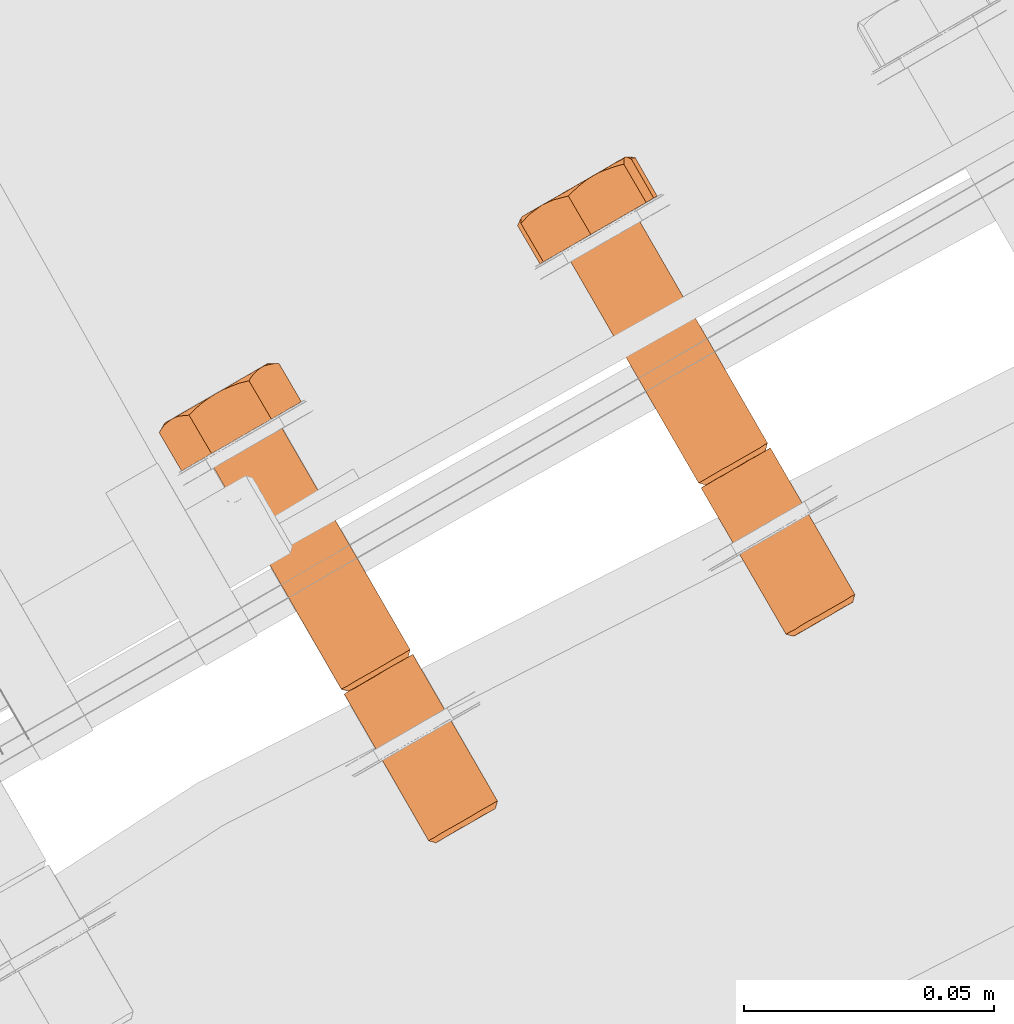
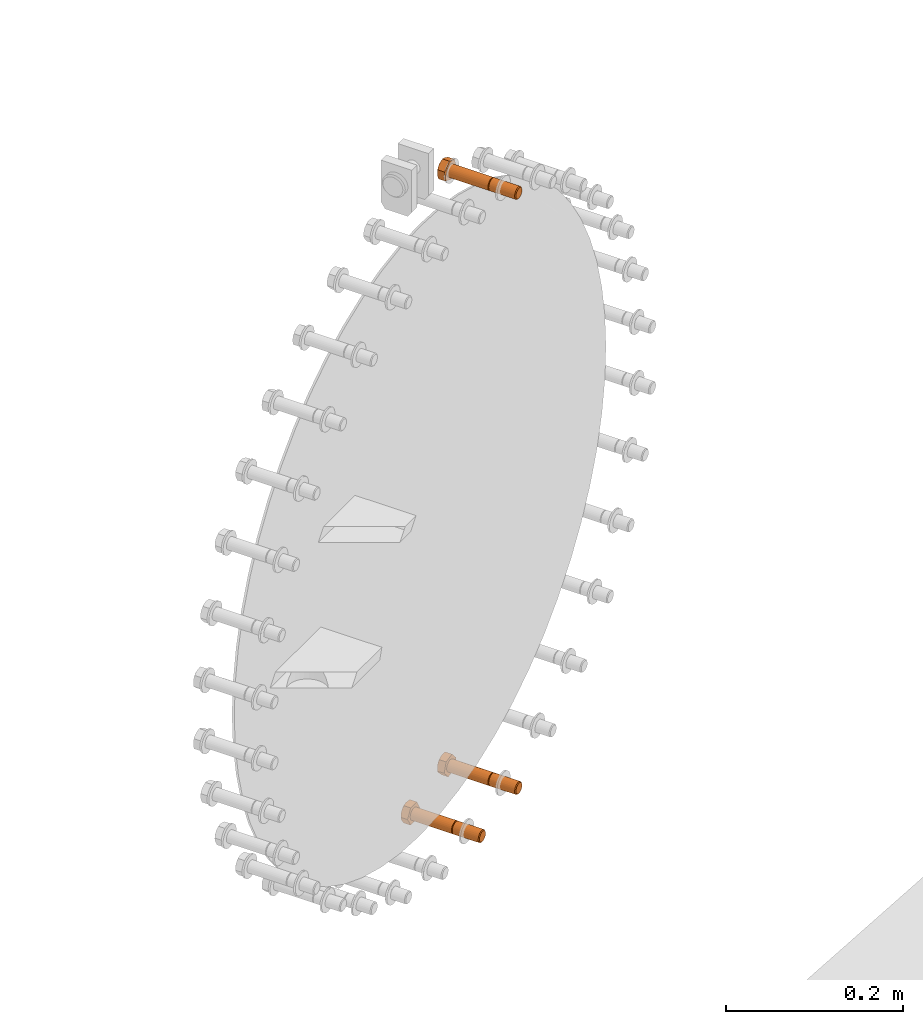
# One storey, part 74 of 126: 3 proxies.
"""IFC2X3 building model written with IfcOpenShell, lengths in millimetres."""

from ifc_helpers import new_model, si_unit, origin, origin_with_axes, place, context, project, spatial, faceted_brep, material, element, save


model = new_model("IFC2X3")

# Units and contexts
context_of_model_1 = context(None, 3, precision=0.1, world=origin())
context_of_model_2 = context(None, 3, precision=0.1, world=origin())
ifc_project = project(units=[si_unit("LENGTHUNIT", "METRE", prefix="MILLI"), si_unit("AREAUNIT", "SQUARE_METRE", prefix="CENTI"), si_unit("VOLUMEUNIT", "CUBIC_METRE", prefix="CENTI"), si_unit("MASSUNIT", "GRAM", prefix="KILO")], contexts=[context_of_model_1, context_of_model_2])

# Site, building, storey
site_placement = place(None, origin_with_axes())
site = spatial("IfcSite", under=ifc_project, at=site_placement, CompositionType="ELEMENT")
building_placement = place(site_placement, origin_with_axes())
building = spatial("IfcBuilding", under=site, at=building_placement, CompositionType="ELEMENT")
storey_placement = place(building_placement, origin_with_axes())
storey = spatial("IfcBuildingStorey", under=building, at=storey_placement, CompositionType="ELEMENT")

# Proxies
ifc_material = material(Name="STAHL")
proxy_1_placement = place(storey_placement, origin_with_axes())
element("IfcBuildingElementProxy", 1, at=proxy_1_placement, inside=storey, material=ifc_material, Name="profile", context=context_of_model_2, shape_type="Brep", body=[
    faceted_brep([(4141.3, 14955.0, 1313.1), (4141.3, 14956.2, 1313.9), (4139.9, 14955.4, 1314.9), (4140.0, 14954.2, 1313.9), (4142.4, 14955.6, 1311.9), (4142.5, 14956.9, 1312.6), (4143.1, 14956.0, 1310.5), (4143.4, 14957.5, 1311.0), (4143.6, 14956.3, 1308.9), (4144.0, 14957.8, 1309.2), (4143.7, 14956.4, 1307.3), (4144.1, 14957.9, 1307.2), (4143.5, 14956.3, 1305.6), (4143.9, 14957.7, 1305.3), (4143.0, 14955.9, 1304.1), (4143.2, 14957.3, 1303.6), (4142.1, 14955.4, 1302.7), (4142.3, 14956.8, 1302.0), (4141.0, 14954.8, 1301.7), (4141.0, 14956.0, 1300.8), (4139.7, 14954.0, 1300.9), (4139.5, 14955.2, 1299.9), (4138.3, 14953.2, 1300.6), (4137.8, 14954.2, 1299.5), (4136.8, 14952.4, 1300.6), (4136.2, 14953.3, 1299.6), (4135.5, 14951.6, 1301.1), (4134.6, 14952.3, 1300.1), (4123.8, 14986.5, 1313.9), (4122.4, 14985.7, 1314.9), (4122.5, 14984.6, 1313.9), (4123.8, 14985.3, 1313.1), (4125.0, 14987.2, 1312.6), (4124.9, 14985.9, 1311.9), (4125.6, 14986.3, 1310.5), (4125.9, 14987.8, 1311.0), (4126.1, 14986.6, 1308.9), (4126.5, 14988.1, 1309.2), (4126.2, 14986.7, 1307.3), (4126.6, 14988.2, 1307.2), (4126.0, 14986.6, 1305.6), (4126.4, 14988.0, 1305.3), (4125.5, 14986.2, 1304.1), (4125.7, 14987.7, 1303.6), (4124.6, 14985.7, 1302.7), (4124.8, 14987.1, 1302.0), (4123.5, 14985.1, 1301.7), (4123.5, 14986.3, 1300.8), (4122.2, 14984.4, 1300.9), (4122.0, 14985.5, 1299.9), (4120.8, 14983.5, 1300.6), (4120.3, 14984.5, 1299.5), (4119.3, 14982.7, 1300.6), (4118.7, 14983.6, 1299.6), (4118.0, 14981.9, 1301.1), (4117.1, 14982.6, 1300.1), (4133.1, 14951.5, 1301.0), (4116.1, 14980.9, 1301.0), (4117.6, 14981.7, 1300.1), (4131.9, 14950.8, 1302.4), (4114.9, 14980.2, 1302.4), (4131.0, 14950.3, 1304.0), (4114.0, 14979.6, 1304.0), (4130.4, 14949.9, 1305.8), (4113.5, 14979.3, 1305.8), (4130.3, 14949.9, 1307.7), (4113.3, 14979.2, 1307.7), (4130.5, 14950.0, 1309.6), (4113.6, 14979.4, 1309.6), (4131.2, 14950.4, 1311.4), (4114.2, 14979.7, 1311.4), (4132.2, 14950.9, 1313.0), (4115.2, 14980.3, 1313.0), (4133.4, 14951.7, 1314.2), (4116.5, 14981.1, 1314.2), (4134.9, 14952.6, 1315.0), (4118.0, 14981.9, 1315.0), (4136.6, 14953.5, 1315.5), (4119.6, 14982.9, 1315.5), (4138.3, 14954.5, 1315.4), (4121.3, 14983.8, 1315.4), (4122.9, 14984.8, 1314.9), (4091.7, 15030.3, 1299.6), (4093.4, 15031.2, 1299.5), (4090.1, 15029.3, 1300.1), (4096.9, 15033.2, 1313.9), (4095.4, 15032.4, 1314.9), (4098.1, 15033.9, 1312.6), (4099.0, 15034.5, 1311.0), (4099.5, 15034.8, 1309.2), (4099.7, 15034.9, 1307.2), (4099.4, 15034.7, 1305.3), (4098.8, 15034.3, 1303.6), (4097.8, 15033.8, 1302.0), (4096.5, 15033.0, 1300.8), (4095.0, 15032.2, 1299.9), (4120.8, 14984.8, 1315.4), (4093.8, 15031.5, 1315.4), (4092.1, 15030.5, 1315.5), (4119.1, 14983.8, 1315.5), (4115.6, 14981.8, 1301.0), (4088.6, 15028.5, 1301.0), (4114.4, 14981.1, 1302.4), (4087.4, 15027.8, 1302.4), (4113.5, 14980.6, 1304.0), (4086.5, 15027.3, 1304.0), (4112.9, 14980.3, 1305.8), (4086.0, 15027.0, 1305.8), (4112.8, 14980.2, 1307.7), (4085.8, 15026.9, 1307.7), (4113.0, 14980.3, 1309.6), (4086.1, 15027.0, 1309.6), (4113.7, 14980.7, 1311.4), (4086.7, 15027.4, 1311.4), (4114.7, 14981.3, 1313.0), (4087.7, 15027.9, 1313.0), (4115.9, 14982.0, 1314.2), (4089.0, 15028.7, 1314.2), (4117.4, 14982.9, 1315.0), (4090.5, 15029.6, 1315.0), (4081.7, 15024.5, 1312.8), (4083.2, 15025.4, 1299.0), (4094.3, 15031.8, 1293.7), (4103.8, 15037.3, 1302.2), (4102.3, 15036.4, 1315.9), (4091.2, 15030.0, 1321.2), (4077.2, 15032.2, 1312.8), (4077.2, 15032.8, 1310.8), (4077.2, 15033.2, 1308.9), (4077.3, 15033.4, 1307.4), (4077.4, 15033.6, 1305.9), (4077.7, 15033.6, 1304.0), (4078.0, 15033.5, 1302.2), (4078.4, 15033.4, 1300.6), (4078.8, 15033.1, 1299.0), (4077.8, 15033.8, 1303.9), (4078.5, 15034.2, 1301.9), (4079.5, 15034.8, 1300.2), (4080.7, 15035.5, 1298.6), (4082.2, 15036.3, 1297.4), (4082.6, 15036.5, 1297.0), (4081.4, 15035.6, 1297.6), (4080.1, 15034.4, 1298.3), (4083.8, 15037.2, 1296.4), (4078.1, 15033.2, 1313.8), (4079.0, 15034.1, 1314.7), (4080.2, 15035.0, 1315.9), (4081.4, 15035.9, 1317.0), (4080.1, 15035.1, 1315.6), (4079.0, 15034.5, 1313.9), (4078.1, 15034.0, 1312.1), (4077.6, 15033.7, 1310.1), (4077.4, 15033.5, 1308.0), (4082.5, 15036.4, 1317.9), (4083.6, 15036.9, 1318.8), (4085.1, 15037.3, 1320.0), (4086.7, 15037.7, 1321.2), (4087.8, 15038.8, 1320.6), (4088.9, 15039.8, 1320.0), (4090.3, 15040.9, 1319.3), (4091.7, 15041.8, 1318.6), (4090.0, 15040.8, 1319.2), (4088.2, 15039.8, 1319.5), (4086.4, 15038.7, 1319.4), (4084.6, 15037.7, 1318.9), (4083.0, 15036.8, 1318.1), (4085.3, 15038.0, 1295.7), (4087.0, 15038.7, 1294.9), (4088.4, 15039.1, 1294.4), (4089.9, 15039.5, 1293.7), (4091.0, 15040.7, 1295.0), (4092.1, 15041.8, 1296.1), (4093.1, 15042.5, 1297.0), (4094.1, 15043.2, 1298.0), (4095.4, 15043.8, 1299.1), (4096.8, 15044.4, 1300.3), (4098.1, 15044.7, 1301.2), (4099.4, 15045.0, 1302.2), (4093.3, 15042.7, 1317.6), (4094.3, 15043.0, 1317.4), (4096.0, 15043.6, 1316.7), (4097.8, 15044.1, 1315.9), (4097.8, 15044.6, 1314.3), (4097.8, 15044.9, 1312.8), (4097.9, 15045.3, 1310.9), (4098.1, 15045.5, 1309.1), (4097.7, 15045.2, 1311.1), (4097.0, 15044.8, 1313.0), (4096.0, 15044.3, 1314.8), (4094.8, 15043.6, 1316.3), (4093.0, 15042.5, 1318.0), (4095.4, 15043.9, 1299.4), (4096.5, 15044.6, 1301.0), (4097.4, 15045.1, 1302.9), (4097.9, 15045.4, 1304.9), (4098.1, 15045.5, 1307.0), (4098.3, 15045.5, 1307.6), (4098.5, 15045.5, 1306.1), (4098.9, 15045.3, 1304.2), (4085.5, 15038.2, 1295.8), (4087.3, 15039.3, 1295.5), (4089.1, 15040.3, 1295.6), (4090.9, 15041.3, 1296.0), (4092.5, 15042.3, 1296.8), (4114.5, 14979.9, 1309.3), (4114.3, 14979.8, 1307.7), (4114.4, 14979.8, 1306.0), (4114.9, 14980.1, 1304.5), (4115.6, 14980.6, 1303.1), (4116.7, 14981.2, 1301.9), (4121.2, 14983.8, 1314.3), (4119.7, 14982.9, 1314.4), (4118.3, 14982.1, 1314.0), (4117.0, 14981.4, 1313.3), (4115.9, 14980.7, 1312.2), (4115.0, 14980.2, 1310.9), (4124.4, 14985.6, 1313.9), (4125.6, 14986.3, 1312.6), (4126.5, 14986.8, 1311.0), (4127.0, 14987.1, 1309.2), (4127.2, 14987.2, 1307.2), (4126.9, 14987.1, 1305.3), (4126.3, 14986.7, 1303.6), (4125.3, 14986.1, 1302.0), (4124.0, 14985.4, 1300.8), (4122.5, 14984.5, 1299.9), (4120.9, 14983.6, 1299.5), (4119.2, 14982.6, 1299.6), (4131.8, 14949.5, 1307.7), (4131.9, 14949.5, 1306.0), (4132.4, 14949.8, 1304.5), (4133.1, 14950.3, 1303.1), (4134.2, 14950.9, 1301.9), (4138.7, 14953.4, 1314.3), (4137.2, 14952.6, 1314.4), (4135.8, 14951.8, 1314.0), (4134.5, 14951.0, 1313.3), (4133.4, 14950.4, 1312.2), (4132.5, 14949.9, 1310.9), (4132.0, 14949.6, 1309.3)], [[[0, 1, 2, 3]], [[4, 5, 1, 0]], [[6, 7, 5, 4]], [[8, 9, 7, 6]], [[10, 11, 9, 8]], [[12, 13, 11, 10]], [[14, 15, 13, 12]], [[16, 17, 15, 14]], [[18, 19, 17, 16]], [[20, 21, 19, 18]], [[22, 23, 21, 20]], [[24, 25, 23, 22]], [[26, 27, 25, 24]], [[28, 29, 30, 31]], [[32, 28, 31, 33]], [[34, 35, 32, 33]], [[36, 37, 35, 34]], [[38, 39, 37, 36]], [[40, 41, 39, 38]], [[42, 43, 41, 40]], [[44, 45, 43, 42]], [[46, 47, 45, 44]], [[48, 49, 47, 46]], [[50, 51, 49, 48]], [[52, 53, 51, 50]], [[54, 55, 53, 52]], [[27, 56, 57, 58]], [[56, 59, 60, 57]], [[59, 61, 62, 60]], [[61, 63, 64, 62]], [[63, 65, 66, 64]], [[65, 67, 68, 66]], [[67, 69, 70, 68]], [[69, 71, 72, 70]], [[71, 73, 74, 72]], [[73, 75, 76, 74]], [[75, 77, 78, 76]], [[77, 79, 80, 78]], [[2, 81, 80, 79]], [[53, 82, 83, 51]], [[55, 84, 82, 53]], [[28, 85, 86, 29]], [[32, 87, 85, 28]], [[35, 88, 87, 32]], [[37, 89, 88, 35]], [[39, 90, 89, 37]], [[41, 91, 90, 39]], [[43, 92, 91, 41]], [[45, 93, 92, 43]], [[47, 94, 93, 45]], [[49, 95, 94, 47]], [[51, 83, 95, 49]], [[96, 29, 86, 97]], [[96, 97, 98, 99]], [[100, 101, 84, 55]], [[102, 103, 101, 100]], [[104, 105, 103, 102]], [[106, 107, 105, 104]], [[108, 109, 107, 106]], [[110, 111, 109, 108]], [[112, 113, 111, 110]], [[114, 115, 113, 112]], [[116, 117, 115, 114]], [[118, 119, 117, 116]], [[99, 98, 119, 118]], [[120, 121, 122, 123, 124, 89, 90, 91, 92, 93, 94, 95, 83, 82, 84, 101, 103, 105, 107, 109, 111, 113, 115, 117, 119, 98, 97, 86, 85, 87, 88, 89, 124, 125]], [[120, 126, 127, 128, 129, 130, 131, 132, 133, 134, 121]], [[134, 133, 132, 131, 130, 135, 136, 137, 138, 139, 140, 141, 142]], [[143, 140, 139]], [[126, 144, 145, 146, 147, 148, 149, 150, 151, 152, 129, 128, 127]], [[130, 129, 152]], [[153, 154, 155, 156, 157, 158, 159, 160, 161, 162, 163, 164, 165]], [[147, 153, 165]], [[121, 134, 142, 141, 140, 143, 166, 167, 168, 169, 122]], [[122, 169, 170, 171, 172, 173, 174, 175, 176, 177, 123]], [[178, 179, 180, 181, 182, 183, 184, 185, 186, 187, 188, 189]], [[190, 179, 178]], [[160, 190, 178]], [[173, 191, 192, 193, 194, 195, 196, 197, 198, 177, 176, 175, 174]], [[185, 196, 195]], [[143, 199, 200, 201, 202, 203, 172, 171, 170, 169, 168, 167, 166]], [[173, 172, 203]], [[124, 123, 177, 198, 197, 196, 185, 184, 183, 182, 181]], [[125, 124, 181, 180, 179, 190, 160, 159, 158, 157, 156]], [[120, 125, 156, 155, 154, 153, 147, 146, 145, 144, 126]], [[152, 151, 150, 149, 148, 147, 165, 164, 163, 162, 161, 160, 178, 189, 188, 187, 186, 185, 195, 194, 193, 192, 191, 173, 203, 202, 201, 200, 199, 143, 139, 138, 137, 136, 135, 130]], [[66, 204, 205, 206, 207, 208, 209, 54, 52, 50, 48, 46, 44, 42, 40, 38, 36, 34, 33, 31, 30, 210, 211, 212, 213, 214, 215, 204, 66, 68, 70, 72, 74, 76, 78, 80, 81, 216, 217, 218, 219, 220, 221, 222, 223, 224, 225, 226, 227, 58, 57, 60, 62, 64]], [[209, 100, 55, 54]], [[208, 102, 100, 209]], [[207, 104, 102, 208]], [[206, 106, 104, 207]], [[205, 108, 106, 206]], [[204, 110, 108, 205]], [[215, 112, 110, 204]], [[214, 114, 112, 215]], [[213, 116, 114, 214]], [[212, 118, 116, 213]], [[211, 99, 118, 212]], [[210, 96, 99, 211]], [[30, 29, 96, 210]], [[27, 58, 227, 25]], [[1, 216, 81, 2]], [[5, 217, 216, 1]], [[7, 218, 217, 5]], [[9, 219, 218, 7]], [[11, 220, 219, 9]], [[13, 221, 220, 11]], [[15, 222, 221, 13]], [[17, 223, 222, 15]], [[19, 224, 223, 17]], [[21, 225, 224, 19]], [[23, 226, 225, 21]], [[25, 227, 226, 23]], [[228, 229, 230, 231, 232, 26, 24, 22, 20, 18, 16, 14, 12, 10, 8, 6, 4, 0, 3, 233, 234, 235, 236, 237, 238, 239]], [[56, 27, 26, 232]], [[59, 56, 232, 231]], [[61, 59, 231, 230]], [[63, 61, 230, 229]], [[65, 63, 229, 228]], [[67, 65, 228, 239]], [[69, 67, 239, 238]], [[71, 69, 238, 237]], [[73, 71, 237, 236]], [[75, 73, 236, 235]], [[77, 75, 235, 234]], [[79, 77, 234, 233]], [[2, 79, 233, 3]]]),
])
proxy_2_placement = place(storey_placement, origin_with_axes())
element("IfcBuildingElementProxy", 2, at=proxy_2_placement, inside=storey, material=ifc_material, Name="profile", context=context_of_model_2, shape_type="Brep", body=[
    faceted_brep([(4137.5, 14952.8, 477.6), (4136.9, 14953.7, 476.5), (4138.6, 14954.6, 476.7), (4138.9, 14953.6, 477.7), (4135.2, 14952.7, 476.8), (4136.1, 14951.9, 477.9), (4133.7, 14951.8, 477.6), (4134.7, 14951.2, 478.5), (4132.4, 14951.1, 478.8), (4133.6, 14950.5, 479.5), (4131.3, 14950.5, 480.3), (4132.7, 14950.0, 480.8), (4130.6, 14950.1, 482.0), (4132.1, 14949.6, 482.4), (4130.3, 14949.9, 483.9), (4131.8, 14949.5, 484.0), (4130.4, 14949.9, 485.8), (4131.8, 14949.5, 485.7), (4130.8, 14950.2, 487.7), (4132.2, 14949.7, 487.3), (4131.7, 14950.7, 489.4), (4133.0, 14950.2, 488.7), (4132.9, 14951.3, 490.7), (4134.0, 14950.7, 489.9), (4134.3, 14952.2, 491.8), (4135.2, 14951.5, 490.8), (4135.9, 14953.1, 492.4), (4136.6, 14952.2, 491.3), (4120.0, 14983.1, 477.6), (4119.4, 14984.0, 476.5), (4121.1, 14984.9, 476.7), (4121.4, 14983.9, 477.7), (4118.6, 14982.3, 477.9), (4117.7, 14983.0, 476.8), (4117.2, 14981.5, 478.5), (4116.2, 14982.1, 477.6), (4116.1, 14980.8, 479.5), (4114.9, 14981.4, 478.8), (4115.2, 14980.3, 480.8), (4113.8, 14980.8, 480.3), (4114.6, 14979.9, 482.4), (4113.1, 14980.4, 482.0), (4114.3, 14979.8, 484.0), (4112.8, 14980.2, 483.9), (4114.3, 14979.8, 485.7), (4112.9, 14980.2, 485.8), (4114.7, 14980.1, 487.3), (4113.3, 14980.5, 487.7), (4115.5, 14980.5, 488.7), (4114.2, 14981.0, 489.4), (4116.5, 14981.1, 489.9), (4115.4, 14981.7, 490.7), (4117.7, 14981.8, 490.8), (4116.8, 14982.5, 491.8), (4119.1, 14982.6, 491.3), (4118.4, 14983.4, 492.4), (4121.6, 14984.0, 476.7), (4123.2, 14984.9, 477.3), (4140.1, 14955.6, 477.3), (4137.5, 14954.0, 492.5), (4120.6, 14983.4, 492.5), (4118.9, 14982.4, 492.4), (4139.2, 14955.0, 492.2), (4122.2, 14984.4, 492.2), (4140.7, 14955.9, 491.4), (4123.7, 14985.2, 491.4), (4142.0, 14956.6, 490.3), (4125.1, 14986.0, 490.3), (4143.1, 14957.2, 488.8), (4126.1, 14986.6, 488.8), (4143.8, 14957.7, 487.0), (4126.8, 14987.0, 487.0), (4144.1, 14957.8, 485.1), (4127.2, 14987.2, 485.1), (4144.0, 14957.8, 483.2), (4127.1, 14987.2, 483.2), (4143.6, 14957.5, 481.3), (4126.6, 14986.9, 481.3), (4142.7, 14957.0, 479.7), (4125.8, 14986.4, 479.7), (4141.6, 14956.4, 478.3), (4124.6, 14985.7, 478.3), (4092.4, 15030.7, 476.5), (4094.1, 15031.6, 476.7), (4090.8, 15029.7, 476.8), (4089.3, 15028.8, 477.6), (4087.9, 15028.1, 478.8), (4086.9, 15027.5, 480.3), (4086.2, 15027.1, 482.0), (4085.8, 15026.9, 483.9), (4085.9, 15026.9, 485.8), (4086.4, 15027.2, 487.7), (4087.2, 15027.7, 489.4), (4088.4, 15028.3, 490.7), (4089.8, 15029.2, 491.8), (4091.4, 15030.1, 492.4), (4120.0, 14984.3, 492.5), (4093.1, 15031.0, 492.5), (4121.7, 14985.3, 492.2), (4094.7, 15032.0, 492.2), (4123.2, 14986.2, 491.4), (4096.2, 15032.9, 491.4), (4124.5, 14987.0, 490.3), (4097.6, 15033.6, 490.3), (4125.6, 14987.6, 488.8), (4098.6, 15034.3, 488.8), (4126.3, 14988.0, 487.0), (4099.3, 15034.7, 487.0), (4126.6, 14988.2, 485.1), (4099.7, 15034.9, 485.1), (4126.5, 14988.1, 483.2), (4099.6, 15034.8, 483.2), (4126.1, 14987.8, 481.3), (4099.1, 15034.5, 481.3), (4125.2, 14987.4, 479.7), (4098.3, 15034.0, 479.7), (4124.1, 14986.7, 478.3), (4097.1, 15033.4, 478.3), (4122.6, 14985.9, 477.3), (4095.7, 15032.6, 477.3), (4081.0, 15024.1, 481.8), (4088.9, 15028.6, 471.4), (4100.7, 15035.4, 474.1), (4104.5, 15037.7, 487.2), (4096.6, 15033.1, 497.6), (4084.8, 15026.3, 494.9), (4100.1, 15045.4, 487.2), (4098.7, 15045.2, 488.7), (4097.4, 15044.8, 490.2), (4096.5, 15044.5, 491.3), (4095.6, 15044.0, 492.4), (4094.5, 15043.3, 493.8), (4093.6, 15042.5, 495.3), (4092.8, 15041.7, 496.4), (4092.1, 15040.8, 497.6), (4087.0, 15039.0, 496.6), (4088.4, 15039.7, 496.9), (4090.2, 15040.3, 497.3), (4094.3, 15043.3, 493.9), (4092.7, 15042.4, 495.0), (4091.1, 15041.5, 495.9), (4089.3, 15040.4, 496.4), (4087.5, 15039.4, 496.5), (4085.7, 15038.4, 496.3), (4099.4, 15045.5, 485.7), (4098.8, 15045.5, 484.2), (4098.2, 15045.4, 482.4), (4097.6, 15045.2, 480.7), (4098.0, 15045.5, 482.7), (4098.1, 15045.5, 484.8), (4097.9, 15045.4, 486.9), (4097.4, 15045.1, 488.9), (4096.6, 15044.7, 490.7), (4089.8, 15040.7, 472.7), (4091.5, 15041.7, 473.3), (4093.1, 15042.6, 474.3), (4094.6, 15043.5, 475.5), (4095.9, 15044.2, 477.0), (4096.9, 15044.8, 478.7), (4096.9, 15044.5, 477.8), (4096.5, 15043.9, 476.0), (4096.2, 15043.2, 474.1), (4094.6, 15042.7, 473.8), (4093.2, 15042.3, 473.5), (4091.4, 15041.5, 473.1), (4097.2, 15044.9, 479.2), (4084.2, 15037.3, 495.9), (4082.7, 15036.2, 495.5), (4081.5, 15035.2, 495.2), (4080.4, 15034.0, 494.9), (4079.6, 15034.1, 493.0), (4078.9, 15034.1, 491.2), (4078.4, 15034.0, 489.8), (4077.9, 15033.8, 488.4), (4077.4, 15033.5, 486.6), (4077.0, 15032.9, 484.8), (4076.8, 15032.4, 483.3), (4076.5, 15031.8, 481.8), (4079.9, 15035.0, 476.6), (4081.2, 15035.8, 475.2), (4082.8, 15036.6, 474.0), (4084.4, 15037.6, 473.2), (4086.2, 15038.6, 472.7), (4088.0, 15039.7, 472.5), (4088.5, 15039.9, 472.4), (4087.3, 15039.0, 472.2), (4085.9, 15037.8, 471.8), (4084.4, 15036.4, 471.4), (4083.3, 15036.2, 472.6), (4082.3, 15036.0, 473.8), (4081.1, 15035.6, 475.2), (4077.5, 15033.6, 486.3), (4077.4, 15033.5, 484.3), (4077.6, 15033.6, 482.2), (4078.1, 15033.9, 480.2), (4078.9, 15034.4, 478.3), (4079.1, 15034.5, 477.7), (4078.3, 15033.8, 478.9), (4077.4, 15032.9, 480.3), (4084.0, 15037.3, 495.7), (4082.4, 15036.4, 494.8), (4080.9, 15035.6, 493.5), (4079.6, 15034.8, 492.0), (4078.6, 15034.3, 490.3), (4113.3, 14979.2, 483.9), (4113.4, 14979.3, 485.8), (4113.9, 14979.6, 487.7), (4114.7, 14980.0, 489.4), (4115.9, 14980.7, 490.7), (4117.3, 14981.5, 491.8), (4119.9, 14983.0, 476.5), (4122.8, 14984.7, 478.2), (4124.0, 14985.4, 479.1), (4125.0, 14986.0, 480.3), (4125.8, 14986.4, 481.8), (4126.2, 14986.6, 483.4), (4126.2, 14986.7, 485.0), (4125.9, 14986.5, 486.7), (4125.3, 14986.2, 488.2), (4124.4, 14985.6, 489.5), (4123.3, 14985.0, 490.5), (4121.9, 14984.2, 491.2), (4120.5, 14983.4, 491.4), (4118.3, 14982.1, 476.8), (4116.8, 14981.2, 477.6), (4115.4, 14980.4, 478.8), (4114.4, 14979.8, 480.3), (4113.7, 14979.4, 482.0), (4140.3, 14954.4, 478.2), (4141.5, 14955.1, 479.1), (4142.5, 14955.7, 480.3), (4143.3, 14956.1, 481.8), (4143.7, 14956.3, 483.4), (4143.7, 14956.4, 485.0), (4143.4, 14956.2, 486.7), (4142.8, 14955.9, 488.2), (4141.9, 14955.3, 489.5), (4140.8, 14954.7, 490.5), (4139.4, 14953.9, 491.2), (4138.0, 14953.1, 491.4)], [[[0, 1, 2, 3]], [[4, 1, 0, 5]], [[6, 4, 5, 7]], [[8, 6, 7, 9]], [[10, 8, 9, 11]], [[12, 10, 11, 13]], [[14, 12, 13, 15]], [[16, 14, 15, 17]], [[18, 16, 17, 19]], [[20, 18, 19, 21]], [[22, 20, 21, 23]], [[24, 22, 23, 25]], [[26, 24, 25, 27]], [[28, 29, 30, 31]], [[32, 33, 29, 28]], [[34, 35, 33, 32]], [[36, 37, 35, 34]], [[38, 39, 37, 36]], [[40, 41, 39, 38]], [[42, 43, 41, 40]], [[44, 45, 43, 42]], [[46, 47, 45, 44]], [[48, 49, 47, 46]], [[50, 51, 49, 48]], [[52, 53, 51, 50]], [[54, 55, 53, 52]], [[2, 56, 57, 58]], [[59, 60, 61, 26]], [[62, 63, 60, 59]], [[64, 65, 63, 62]], [[66, 67, 65, 64]], [[68, 69, 67, 66]], [[70, 71, 69, 68]], [[72, 73, 71, 70]], [[74, 75, 73, 72]], [[76, 77, 75, 74]], [[78, 79, 77, 76]], [[80, 81, 79, 78]], [[58, 57, 81, 80]], [[29, 82, 83, 30]], [[29, 33, 84, 82]], [[33, 35, 85, 84]], [[35, 37, 86, 85]], [[37, 39, 87, 86]], [[39, 41, 88, 87]], [[41, 43, 89, 88]], [[43, 45, 90, 89]], [[45, 47, 91, 90]], [[47, 49, 92, 91]], [[49, 51, 93, 92]], [[51, 53, 94, 93]], [[53, 55, 95, 94]], [[96, 97, 95, 55]], [[96, 98, 99, 97]], [[98, 100, 101, 99]], [[100, 102, 103, 101]], [[102, 104, 105, 103]], [[104, 106, 107, 105]], [[106, 108, 109, 107]], [[108, 110, 111, 109]], [[110, 112, 113, 111]], [[112, 114, 115, 113]], [[114, 116, 117, 115]], [[116, 118, 119, 117]], [[118, 30, 83, 119]], [[120, 121, 86, 87, 88, 89, 90, 91, 92, 93, 94, 95, 97, 99, 101, 103, 105, 107, 109, 111, 113, 115, 117, 119, 83, 82, 84, 85, 86, 121, 122, 123, 124, 125]], [[124, 123, 126, 127, 128, 129, 130, 131, 132, 133, 134]], [[135, 136, 137, 134, 133, 132, 131, 130, 138, 139, 140, 141, 142]], [[143, 135, 142]], [[129, 128, 127, 126, 144, 145, 146, 147, 148, 149, 150, 151, 152]], [[130, 129, 152]], [[153, 154, 155, 156, 157, 158, 159, 160, 161, 162, 163, 164]], [[165, 159, 158]], [[147, 165, 158]], [[125, 124, 134, 137, 136, 135, 143, 166, 167, 168, 169]], [[120, 125, 169, 170, 171, 172, 173, 174, 175, 176, 177]], [[178, 179, 180, 181, 182, 183, 184, 185, 186, 187, 188, 189, 190]], [[153, 184, 183]], [[177, 176, 175, 174, 173, 191, 192, 193, 194, 195, 196, 197, 198]], [[178, 196, 195]], [[169, 168, 167, 166, 143, 199, 200, 201, 202, 203, 171, 170]], [[172, 171, 203]], [[173, 172, 203]], [[120, 177, 198, 197, 196, 178, 190, 189, 188, 187, 121]], [[121, 187, 186, 185, 184, 153, 164, 163, 162, 161, 122]], [[122, 161, 160, 159, 165, 147, 146, 145, 144, 126, 123]], [[192, 191, 173, 203, 202, 201, 200, 199, 143, 142, 141, 140, 139, 138, 130, 152, 151, 150, 149, 148, 147, 158, 157, 156, 155, 154, 153, 183, 182, 181, 180, 179, 178, 195, 194, 193]], [[204, 205, 206, 207, 208, 209, 61, 60, 63, 65, 67, 69, 71, 73, 75, 77, 79, 81, 57, 56, 210, 28, 31, 211, 212, 213, 214, 215, 216, 217, 218, 219, 220, 221, 222, 54, 52, 50, 48, 46, 44, 42, 40, 38, 36, 34, 32, 28, 210, 223, 224, 225, 226, 227]], [[96, 55, 54, 222]], [[98, 96, 222, 221]], [[100, 98, 221, 220]], [[102, 100, 220, 219]], [[104, 102, 219, 218]], [[106, 104, 218, 217]], [[108, 106, 217, 216]], [[110, 108, 216, 215]], [[112, 110, 215, 214]], [[114, 112, 214, 213]], [[116, 114, 213, 212]], [[118, 116, 212, 211]], [[30, 118, 211, 31]], [[2, 1, 210, 56]], [[1, 4, 223, 210]], [[4, 6, 224, 223]], [[6, 8, 225, 224]], [[8, 10, 226, 225]], [[10, 12, 227, 226]], [[12, 14, 204, 227]], [[14, 16, 205, 204]], [[16, 18, 206, 205]], [[18, 20, 207, 206]], [[20, 22, 208, 207]], [[22, 24, 209, 208]], [[24, 26, 61, 209]], [[15, 13, 11, 9, 7, 5, 0, 3, 228, 229, 230, 231, 232, 233, 234, 235, 236, 237, 238, 239, 27, 25, 23, 21, 19, 17]], [[239, 59, 26, 27]], [[238, 62, 59, 239]], [[237, 64, 62, 238]], [[236, 66, 64, 237]], [[235, 68, 66, 236]], [[234, 70, 68, 235]], [[233, 72, 70, 234]], [[232, 74, 72, 233]], [[231, 76, 74, 232]], [[230, 78, 76, 231]], [[229, 80, 78, 230]], [[228, 58, 80, 229]], [[3, 2, 58, 228]]]),
])
proxy_3_placement = place(storey_placement, origin_with_axes())
element("IfcBuildingElementProxy", 3, at=proxy_3_placement, inside=storey, material=ifc_material, Name="profile", context=context_of_model_2, shape_type="Brep", body=[
    faceted_brep([(4064.7, 14910.8, 461.4), (4064.0, 14911.6, 460.3), (4065.6, 14912.5, 460.1), (4066.2, 14911.6, 461.2), (4063.4, 14910.0, 461.9), (4062.4, 14910.7, 461.0), (4062.2, 14909.3, 462.9), (4061.0, 14909.9, 462.1), (4061.2, 14908.7, 464.1), (4059.9, 14909.2, 463.5), (4060.5, 14908.3, 465.6), (4059.1, 14908.8, 465.2), (4060.2, 14908.1, 467.2), (4058.7, 14908.5, 467.1), (4060.2, 14908.1, 468.9), (4058.7, 14908.5, 469.0), (4060.5, 14908.3, 470.5), (4059.1, 14908.8, 470.9), (4061.2, 14908.7, 472.0), (4059.9, 14909.2, 472.6), (4062.2, 14909.3, 473.2), (4061.0, 14909.9, 474.1), (4063.4, 14910.0, 474.2), (4062.4, 14910.7, 475.2), (4064.7, 14910.8, 474.8), (4064.0, 14911.6, 475.8), (4066.2, 14911.6, 475.0), (4065.6, 14912.5, 476.1), (4047.2, 14941.1, 461.4), (4046.5, 14941.9, 460.3), (4048.1, 14942.8, 460.1), (4048.7, 14941.9, 461.2), (4045.9, 14940.3, 461.9), (4044.9, 14941.0, 461.0), (4044.7, 14939.6, 462.9), (4043.5, 14940.2, 462.1), (4043.7, 14939.0, 464.1), (4042.4, 14939.5, 463.5), (4043.0, 14938.7, 465.6), (4041.6, 14939.1, 465.2), (4042.7, 14938.5, 467.2), (4041.2, 14938.9, 467.1), (4042.7, 14938.5, 468.9), (4041.2, 14938.9, 469.0), (4043.0, 14938.7, 470.5), (4041.6, 14939.1, 470.9), (4043.7, 14939.0, 472.0), (4042.4, 14939.5, 472.6), (4044.7, 14939.6, 473.2), (4043.5, 14940.2, 474.1), (4045.9, 14940.3, 474.2), (4044.9, 14941.0, 475.2), (4047.2, 14941.1, 474.8), (4046.5, 14941.9, 475.8), (4048.7, 14941.9, 475.0), (4048.1, 14942.8, 476.1), (4048.7, 14941.9, 460.1), (4050.3, 14942.9, 460.3), (4067.3, 14913.5, 460.3), (4067.3, 14913.5, 475.8), (4050.3, 14942.9, 475.8), (4048.7, 14941.9, 476.1), (4068.8, 14914.4, 475.2), (4051.9, 14943.8, 475.2), (4070.2, 14915.2, 474.1), (4053.2, 14944.5, 474.1), (4071.3, 14915.8, 472.6), (4054.4, 14945.2, 472.6), (4072.1, 14916.3, 470.9), (4055.1, 14945.6, 470.9), (4072.5, 14916.5, 469.0), (4055.5, 14945.9, 469.0), (4072.5, 14916.5, 467.1), (4055.5, 14945.9, 467.1), (4072.1, 14916.3, 465.2), (4055.1, 14945.6, 465.2), (4071.3, 14915.8, 463.5), (4054.4, 14945.2, 463.5), (4070.2, 14915.2, 462.1), (4053.2, 14944.5, 462.1), (4068.8, 14914.4, 461.0), (4051.9, 14943.8, 461.0), (4021.2, 14989.5, 476.1), (4019.5, 14988.6, 475.8), (4017.9, 14987.7, 475.2), (4019.5, 14988.6, 460.3), (4021.2, 14989.5, 460.1), (4017.9, 14987.7, 461.0), (4016.6, 14986.9, 462.1), (4015.4, 14986.2, 463.5), (4014.7, 14985.8, 465.2), (4014.3, 14985.6, 467.1), (4014.3, 14985.6, 469.0), (4014.7, 14985.8, 470.9), (4015.4, 14986.2, 472.6), (4016.6, 14986.9, 474.1), (4049.8, 14943.8, 460.3), (4022.8, 14990.5, 460.3), (4024.4, 14991.4, 461.0), (4051.3, 14944.7, 461.0), (4049.8, 14943.8, 475.8), (4022.8, 14990.5, 475.8), (4051.3, 14944.7, 475.2), (4024.4, 14991.4, 475.2), (4052.7, 14945.5, 474.1), (4025.7, 14992.2, 474.1), (4053.8, 14946.1, 472.6), (4026.9, 14992.8, 472.6), (4054.6, 14946.6, 470.9), (4027.6, 14993.3, 470.9), (4055.0, 14946.8, 469.0), (4028.0, 14993.5, 469.0), (4055.0, 14946.8, 467.1), (4028.0, 14993.5, 467.1), (4054.6, 14946.6, 465.2), (4027.6, 14993.3, 465.2), (4053.8, 14946.1, 463.5), (4026.9, 14992.8, 463.5), (4052.7, 14945.5, 462.1), (4025.7, 14992.2, 462.1), (4009.2, 14982.6, 468.1), (4015.2, 14986.1, 456.1), (4027.2, 14993.0, 456.1), (4033.2, 14996.5, 468.1), (4027.2, 14993.0, 480.1), (4015.2, 14986.1, 480.1), (4028.7, 15004.2, 468.1), (4027.6, 15004.1, 469.8), (4026.6, 15003.9, 471.5), (4025.8, 15003.7, 472.8), (4025.2, 15003.4, 474.1), (4024.4, 15002.8, 475.7), (4023.7, 15002.1, 477.3), (4023.2, 15001.5, 478.7), (4022.7, 15000.7, 480.1), (4018.0, 14999.2, 479.9), (4018.9, 14999.5, 480.1), (4020.7, 15000.2, 480.1), (4024.1, 15002.8, 475.8), (4022.8, 15002.0, 477.3), (4021.3, 15001.2, 478.5), (4019.7, 15000.2, 479.3), (4017.5, 14998.9, 480.1), (4016.2, 14998.2, 480.1), (4025.2, 15003.4, 462.1), (4025.9, 15003.8, 464.0), (4026.4, 15004.1, 466.0), (4026.5, 15004.2, 468.1), (4026.4, 15004.1, 470.2), (4025.9, 15003.8, 472.2), (4027.8, 15004.1, 466.7), (4027.0, 15004.0, 465.3), (4026.0, 15003.8, 463.7), (4016.2, 14998.2, 456.1), (4018.0, 14999.2, 456.3), (4019.7, 15000.2, 456.8), (4021.3, 15001.2, 457.7), (4022.8, 15002.0, 458.9), (4024.1, 15002.8, 460.4), (4024.5, 15003.0, 460.8), (4023.9, 15002.4, 459.5), (4023.3, 15001.7, 457.8), (4022.7, 15000.7, 456.1), (4021.1, 15000.3, 456.1), (4019.6, 14999.8, 456.1), (4017.8, 14999.1, 456.1), (4014.6, 14997.2, 480.1), (4013.0, 14996.0, 480.1), (4011.9, 14995.0, 480.1), (4010.7, 14993.8, 480.1), (4009.6, 14993.7, 478.3), (4008.6, 14993.6, 476.7), (4007.8, 14993.3, 475.4), (4007.2, 14993.0, 474.1), (4006.4, 14992.4, 472.4), (4005.7, 14991.8, 470.8), (4005.2, 14991.1, 469.5), (4004.7, 14990.3, 468.1), (4007.2, 14993.0, 462.1), (4008.2, 14993.6, 460.4), (4009.5, 14994.3, 458.9), (4011.0, 14995.2, 457.7), (4012.6, 14996.1, 456.8), (4014.3, 14997.1, 456.3), (4014.9, 14997.4, 456.1), (4013.6, 14996.5, 456.1), (4012.1, 14995.2, 456.1), (4010.7, 14993.8, 456.1), (4009.8, 14993.8, 457.5), (4009.0, 14993.6, 458.8), (4008.0, 14993.4, 460.4), (4006.4, 14992.5, 472.2), (4005.9, 14992.3, 470.2), (4005.8, 14992.2, 468.1), (4005.9, 14992.3, 466.0), (4006.4, 14992.5, 464.0), (4006.5, 14992.6, 463.4), (4005.9, 14992.0, 464.7), (4005.3, 14991.3, 466.3), (4014.3, 14997.1, 479.9), (4012.6, 14996.1, 479.3), (4011.0, 14995.2, 478.5), (4009.5, 14994.3, 477.3), (4008.2, 14993.6, 475.8), (4041.8, 14937.9, 467.1), (4041.8, 14937.9, 469.0), (4042.2, 14938.2, 470.9), (4042.9, 14938.6, 472.6), (4044.1, 14939.2, 474.1), (4045.4, 14940.0, 475.2), (4047.0, 14940.9, 475.8), (4047.0, 14940.9, 460.3), (4050.1, 14942.7, 461.4), (4051.4, 14943.5, 461.9), (4052.6, 14944.2, 462.9), (4053.6, 14944.7, 464.1), (4054.3, 14945.1, 465.6), (4054.6, 14945.3, 467.2), (4054.6, 14945.3, 468.9), (4054.3, 14945.1, 470.5), (4053.6, 14944.7, 472.0), (4052.6, 14944.2, 473.2), (4051.4, 14943.5, 474.2), (4050.1, 14942.7, 474.8), (4045.4, 14940.0, 461.0), (4044.1, 14939.2, 462.1), (4042.9, 14938.6, 463.5), (4042.2, 14938.2, 465.2), (4067.6, 14912.4, 461.4), (4068.9, 14913.2, 461.9), (4070.1, 14913.9, 462.9), (4071.1, 14914.4, 464.1), (4071.8, 14914.8, 465.6), (4072.1, 14915.0, 467.2), (4072.1, 14915.0, 468.9), (4071.8, 14914.8, 470.5), (4071.1, 14914.4, 472.0), (4070.1, 14913.9, 473.2), (4068.9, 14913.2, 474.2), (4067.6, 14912.4, 474.8)], [[[0, 1, 2, 3]], [[4, 5, 1, 0]], [[6, 7, 5, 4]], [[8, 9, 7, 6]], [[10, 11, 9, 8]], [[12, 13, 11, 10]], [[14, 15, 13, 12]], [[16, 17, 15, 14]], [[18, 19, 17, 16]], [[20, 21, 19, 18]], [[22, 23, 21, 20]], [[24, 25, 23, 22]], [[26, 27, 25, 24]], [[28, 29, 30, 31]], [[32, 33, 29, 28]], [[34, 35, 33, 32]], [[36, 37, 35, 34]], [[38, 39, 37, 36]], [[40, 41, 39, 38]], [[42, 43, 41, 40]], [[44, 45, 43, 42]], [[46, 47, 45, 44]], [[48, 49, 47, 46]], [[50, 51, 49, 48]], [[52, 53, 51, 50]], [[54, 55, 53, 52]], [[2, 56, 57, 58]], [[59, 60, 61, 27]], [[62, 63, 60, 59]], [[64, 65, 63, 62]], [[66, 67, 65, 64]], [[68, 69, 67, 66]], [[70, 71, 69, 68]], [[72, 73, 71, 70]], [[74, 75, 73, 72]], [[76, 77, 75, 74]], [[78, 79, 77, 76]], [[80, 81, 79, 78]], [[58, 57, 81, 80]], [[53, 55, 82, 83]], [[53, 83, 84, 51]], [[30, 29, 85, 86]], [[33, 87, 85, 29]], [[35, 88, 87, 33]], [[37, 89, 88, 35]], [[39, 90, 89, 37]], [[41, 91, 90, 39]], [[43, 92, 91, 41]], [[45, 93, 92, 43]], [[47, 94, 93, 45]], [[49, 95, 94, 47]], [[51, 84, 95, 49]], [[96, 97, 98, 99]], [[30, 86, 97, 96]], [[100, 101, 82, 55]], [[102, 103, 101, 100]], [[104, 105, 103, 102]], [[106, 107, 105, 104]], [[108, 109, 107, 106]], [[110, 111, 109, 108]], [[112, 113, 111, 110]], [[114, 115, 113, 112]], [[116, 117, 115, 114]], [[118, 119, 117, 116]], [[99, 98, 119, 118]], [[120, 121, 89, 90, 91, 92, 93, 94, 95, 84, 83, 82, 101, 103, 105, 107, 109, 111, 113, 115, 117, 119, 98, 97, 86, 85, 87, 88, 89, 121, 122, 123, 124, 125]], [[124, 123, 126, 127, 128, 129, 130, 131, 132, 133, 134]], [[135, 136, 137, 134, 133, 132, 131, 130, 138, 139, 140, 141]], [[142, 136, 135]], [[143, 142, 135]], [[144, 145, 146, 147, 148, 149, 129, 128, 127, 126, 150, 151, 152]], [[130, 129, 149]], [[153, 154, 155, 156, 157, 158, 159, 160, 161, 162, 163, 164, 165]], [[144, 159, 158]], [[125, 124, 134, 137, 136, 142, 143, 166, 167, 168, 169]], [[120, 125, 169, 170, 171, 172, 173, 174, 175, 176, 177]], [[178, 179, 180, 181, 182, 183, 184, 185, 186, 187, 188, 189, 190]], [[153, 184, 183]], [[177, 176, 175, 174, 173, 191, 192, 193, 194, 195, 196, 197, 198]], [[178, 196, 195]], [[172, 171, 170, 169, 168, 167, 166, 143, 199, 200, 201, 202, 203]], [[173, 172, 203]], [[120, 177, 198, 197, 196, 178, 190, 189, 188, 187, 121]], [[121, 187, 186, 185, 184, 153, 165, 164, 163, 162, 122]], [[122, 162, 161, 160, 159, 144, 152, 151, 150, 126, 123]], [[193, 192, 191, 173, 203, 202, 201, 200, 199, 143, 135, 141, 140, 139, 138, 130, 149, 148, 147, 146, 145, 144, 158, 157, 156, 155, 154, 153, 183, 182, 181, 180, 179, 178, 195, 194]], [[204, 205, 206, 207, 208, 209, 210, 61, 60, 63, 65, 67, 69, 71, 73, 75, 77, 79, 81, 57, 56, 211, 28, 31, 212, 213, 214, 215, 216, 217, 218, 219, 220, 221, 222, 223, 54, 52, 50, 48, 46, 44, 42, 40, 38, 36, 34, 32, 28, 211, 224, 225, 226, 227]], [[100, 55, 54, 223]], [[102, 100, 223, 222]], [[104, 102, 222, 221]], [[106, 104, 221, 220]], [[108, 106, 220, 219]], [[110, 108, 219, 218]], [[112, 110, 218, 217]], [[114, 112, 217, 216]], [[116, 114, 216, 215]], [[118, 116, 215, 214]], [[99, 118, 214, 213]], [[96, 99, 213, 212]], [[30, 96, 212, 31]], [[27, 61, 210, 25]], [[1, 211, 56, 2]], [[5, 224, 211, 1]], [[7, 225, 224, 5]], [[9, 226, 225, 7]], [[11, 227, 226, 9]], [[13, 204, 227, 11]], [[15, 205, 204, 13]], [[17, 206, 205, 15]], [[19, 207, 206, 17]], [[21, 208, 207, 19]], [[23, 209, 208, 21]], [[25, 210, 209, 23]], [[14, 12, 10, 8, 6, 4, 0, 3, 228, 229, 230, 231, 232, 233, 234, 235, 236, 237, 238, 239, 26, 24, 22, 20, 18, 16]], [[239, 59, 27, 26]], [[238, 62, 59, 239]], [[237, 64, 62, 238]], [[236, 66, 64, 237]], [[235, 68, 66, 236]], [[234, 70, 68, 235]], [[233, 72, 70, 234]], [[232, 74, 72, 233]], [[231, 76, 74, 232]], [[230, 78, 76, 231]], [[229, 80, 78, 230]], [[228, 58, 80, 229]], [[3, 2, 58, 228]]]),
])

save(model, "model.ifc")
